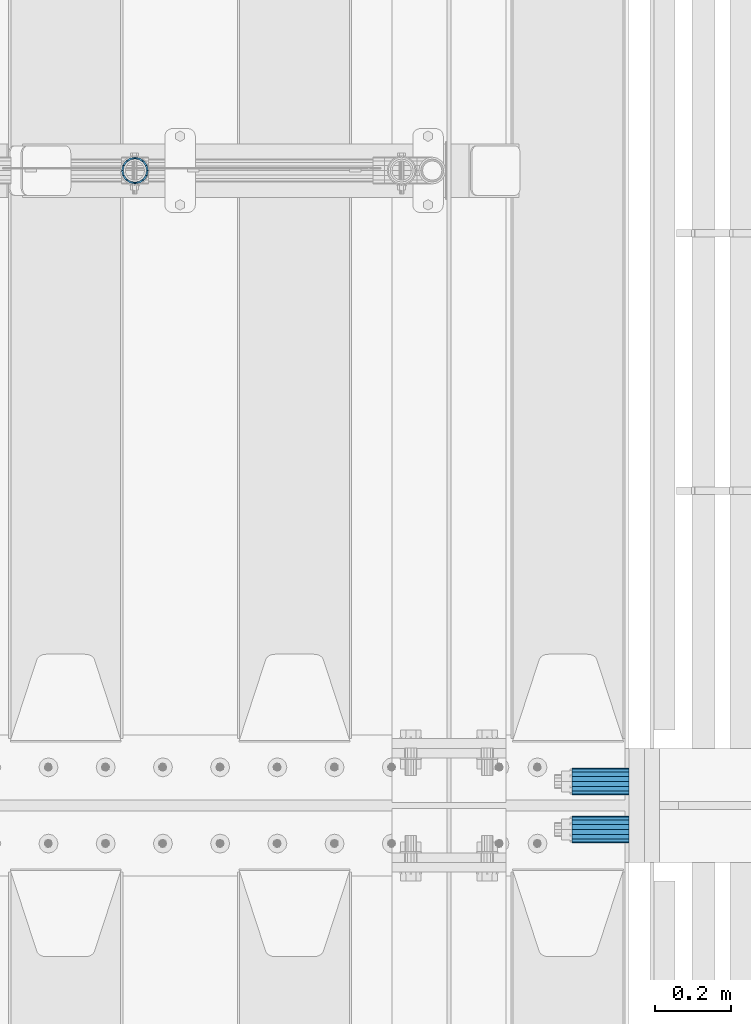
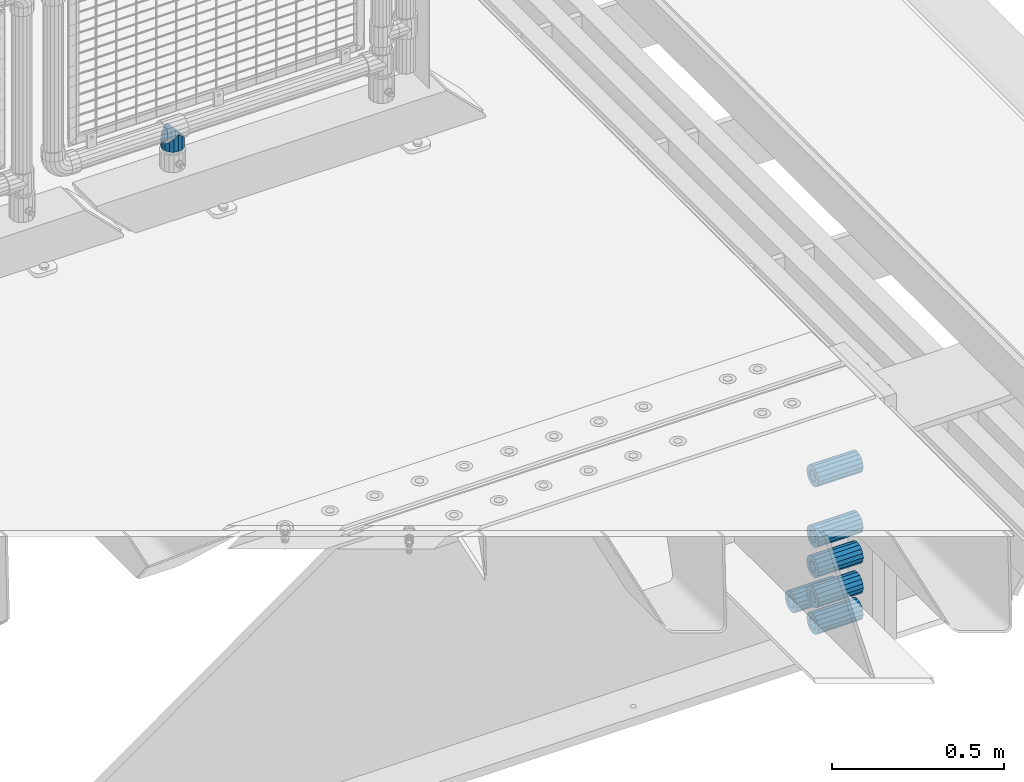
# One storey, part 156 of 240: 7 beams.
"""IFC2X3 building model written with IfcOpenShell, lengths in millimetres."""

from ifc_helpers import new_model, si_unit, frame, origin_with_axes, place, context, subcontext, project, spatial, faceted_brep, material, type_object, element, save


model = new_model("IFC2X3")

# Units and contexts
model_context = context("Model", 3, precision=1e-05, world=origin_with_axes())
body_context = subcontext(model_context, "Body", "Model", "MODEL_VIEW")
ifc_project = project(units=[si_unit("LENGTHUNIT", "METRE", prefix="MILLI"), si_unit("AREAUNIT", "SQUARE_METRE"), si_unit("VOLUMEUNIT", "CUBIC_METRE"), si_unit("MASSUNIT", "GRAM", prefix="KILO"), si_unit("TIMEUNIT", "SECOND"), si_unit("PLANEANGLEUNIT", "RADIAN"), si_unit("SOLIDANGLEUNIT", "STERADIAN"), si_unit("THERMODYNAMICTEMPERATUREUNIT", "DEGREE_CELSIUS"), si_unit("LUMINOUSINTENSITYUNIT", "LUMEN")], contexts=[model_context])

# Site, building, storey
site_placement = place(None, origin_with_axes())
site = spatial("IfcSite", under=ifc_project, at=site_placement, CompositionType="ELEMENT")
building_placement = place(site_placement, origin_with_axes())
building = spatial("IfcBuilding", under=site, at=building_placement, Name="Standard", CompositionType="ELEMENT")
storey_placement = place(building_placement, origin_with_axes())
storey = spatial("IfcBuildingStorey", under=building, at=storey_placement, Name="Undefined", CompositionType="ELEMENT", Elevation=0.0)

# Beams
ifc_material_1 = material()
beam_type_1 = type_object("IfcBeamType", PredefinedType="NOTDEFINED")
beam_1_placement = place(storey_placement, frame((56327.0, 32937.0, -285.0), z_axis=(0.0, 0.0, 1.0), x_axis=(1.0, 0.0, 0.0)))
element("IfcBeam", 1, at=beam_1_placement, inside=storey, type_object=beam_type_1, material=ifc_material_1, context=body_context, shape_type="Brep", body=[
    faceted_brep([(-1.31236447487026e-07, -18.9999999995492, -6.26459950581193e-09), (0.0, -17.5537111177146, 7.27098521493673), (150.0, -17.5537111177146, 7.27098521493673), (150.0, -19.0, 0.0), (0.0, -13.4350288425449, 13.4350288425444), (150.0, -13.4350288425449, 13.4350288425444), (0.0, -7.27098521493826, 17.5537111177144), (150.0, -7.27098521493826, 17.5537111177144), (-6.35918695479631e-09, 4.50199877377599e-10, 18.9999999937281), (150.0, 0.0, 19.0), (0.0, 7.27098521493826, 17.5537111177144), (150.0, 7.27098521493826, 17.5537111177144), (0.0, 13.4350288425449, 13.4350288425444), (150.0, 13.4350288425449, 13.4350288425444), (0.0, 17.5537111177146, 7.27098521493673), (150.0, 17.5537111177146, 7.27098521493673), (1.33248249767348e-07, 19.0000000004507, -6.26459950581193e-09), (150.0, 19.0, 0.0), (0.0, 17.5537111177146, -7.27098521493673), (150.0, 17.5537111177146, -7.27098521493673), (0.0, 13.4350288425449, -13.4350288425444), (150.0, 13.4350288425449, -13.4350288425444), (0.0, 7.27098521493826, -17.5537111177144), (150.0, 7.27098521493826, -17.5537111177144), (8.37098923511803e-09, 4.50313564215321e-10, -19.0000000062646), (150.0, 0.0, -19.0), (0.0, -7.27098521493826, -17.5537111177144), (150.0, -7.27098521493826, -17.5537111177144), (0.0, -13.4350288425449, -13.4350288425444), (150.0, -13.4350288425449, -13.4350288425444), (0.0, -17.5537111177146, -7.27098521493673), (150.0, -17.5537111177146, -7.27098521493673), (0.0, -35.0, 0.0), (7.27595761418343e-12, -32.335783637895, -13.3939201327739), (150.0, -32.3357836378964, -13.3939201327782), (150.0, -35.0, 0.0), (0.0, -24.7487373415292, -24.7487373415279), (150.0, -24.7487373415279, -24.7487373415292), (7.27595761418343e-12, -13.3939201327781, -32.3357836378891), (150.0, -13.3939201327776, -32.335783637895), (7.27595761418343e-12, 0.0, -35.0), (150.0, 0.0, -35.0), (7.27595761418343e-12, 13.3939201327782, -32.3357836378891), (150.0, 13.3939201327776, -32.335783637895), (0.0, 24.7487373415292, -24.7487373415279), (150.0, 24.7487373415279, -24.7487373415291), (7.27595761418343e-12, 32.335783637895, -13.3939201327739), (150.0, 32.3357836378964, -13.3939201327781), (0.0, 35.0, 0.0), (150.0, 35.0, 0.0), (0.0, 32.335783637895, 13.3939201327812), (150.0, 32.3357836378964, 13.3939201327781), (0.0, 24.7487373415292, 24.7487373415279), (150.0, 24.7487373415279, 24.7487373415292), (0.0, 13.3939201327781, 32.3357836378964), (150.0, 13.3939201327776, 32.335783637895), (0.0, 0.0, 35.0), (150.0, 0.0, 35.0), (0.0, -13.3939201327781, 32.3357836378964), (150.0, -13.3939201327776, 32.335783637895), (0.0, -24.7487373415292, 24.7487373415279), (150.0, -24.7487373415279, 24.7487373415292), (0.0, -32.335783637895, 13.3939201327812), (150.0, -32.3357836378964, 13.3939201327781)], [[[0, 1, 2, 3]], [[1, 4, 5, 2]], [[4, 6, 7, 5]], [[6, 8, 9, 7]], [[8, 10, 11, 9]], [[10, 12, 13, 11]], [[12, 14, 15, 13]], [[14, 16, 17, 15]], [[16, 18, 19, 17]], [[18, 20, 21, 19]], [[20, 22, 23, 21]], [[22, 24, 25, 23]], [[24, 26, 27, 25]], [[26, 28, 29, 27]], [[28, 30, 31, 29]], [[30, 0, 3, 31]], [[32, 33, 34, 35]], [[33, 36, 37, 34]], [[36, 38, 39, 37]], [[38, 40, 41, 39]], [[40, 42, 43, 41]], [[42, 44, 45, 43]], [[44, 46, 47, 45]], [[46, 48, 49, 47]], [[48, 50, 51, 49]], [[50, 52, 53, 51]], [[52, 54, 55, 53]], [[54, 56, 57, 55]], [[56, 58, 59, 57]], [[58, 60, 61, 59]], [[60, 62, 63, 61]], [[62, 32, 35, 63]], [[37, 39, 41, 43, 45, 47, 49, 51, 53, 55, 57, 59, 61, 63, 35, 34], [5, 7, 9, 11, 13, 15, 17, 19, 21, 23, 25, 27, 29, 31, 3, 2]], [[62, 60, 58, 56, 54, 52, 50, 48, 46, 44, 42, 40, 38, 36, 33, 32], [30, 28, 26, 24, 22, 20, 18, 16, 14, 12, 10, 8, 6, 4, 1, 0]]]),
])
beam_2_placement = place(storey_placement, frame((56327.0, 32937.0, -499.0), z_axis=(0.0, 0.0, 1.0), x_axis=(1.0, 0.0, 0.0)))
element("IfcBeam", 2, at=beam_2_placement, inside=storey, type_object=beam_type_1, material=ifc_material_1, context=body_context, shape_type="Brep", body=[
    faceted_brep([(-1.31236447487026e-07, -18.9999999995492, -6.26459950581193e-09), (0.0, -17.5537111177146, 7.27098521493673), (150.0, -17.5537111177146, 7.27098521493673), (150.0, -19.0, 0.0), (0.0, -13.4350288425449, 13.4350288425444), (150.0, -13.4350288425449, 13.4350288425444), (0.0, -7.27098521493826, 17.5537111177144), (150.0, -7.27098521493826, 17.5537111177144), (-6.35918695479631e-09, 4.50199877377599e-10, 18.9999999937281), (150.0, 0.0, 19.0), (0.0, 7.27098521493826, 17.5537111177144), (150.0, 7.27098521493826, 17.5537111177144), (0.0, 13.4350288425449, 13.4350288425444), (150.0, 13.4350288425449, 13.4350288425444), (0.0, 17.5537111177146, 7.27098521493673), (150.0, 17.5537111177146, 7.27098521493673), (1.33248249767348e-07, 19.0000000004507, -6.26459950581193e-09), (150.0, 19.0, 0.0), (0.0, 17.5537111177146, -7.27098521493673), (150.0, 17.5537111177146, -7.27098521493673), (0.0, 13.4350288425449, -13.4350288425444), (150.0, 13.4350288425449, -13.4350288425444), (0.0, 7.27098521493826, -17.5537111177144), (150.0, 7.27098521493826, -17.5537111177144), (8.37098923511803e-09, 4.50313564215321e-10, -19.0000000062646), (150.0, 0.0, -19.0), (0.0, -7.27098521493826, -17.5537111177144), (150.0, -7.27098521493826, -17.5537111177144), (0.0, -13.4350288425449, -13.4350288425444), (150.0, -13.4350288425449, -13.4350288425444), (0.0, -17.5537111177146, -7.27098521493673), (150.0, -17.5537111177146, -7.27098521493673), (0.0, -35.0, 0.0), (7.27595761418343e-12, -32.335783637895, -13.3939201327739), (150.0, -32.3357836378964, -13.3939201327782), (150.0, -35.0, 0.0), (0.0, -24.7487373415292, -24.7487373415279), (150.0, -24.7487373415279, -24.7487373415292), (7.27595761418343e-12, -13.3939201327781, -32.3357836378891), (150.0, -13.3939201327776, -32.335783637895), (7.27595761418343e-12, 0.0, -35.0), (150.0, 0.0, -35.0), (7.27595761418343e-12, 13.3939201327782, -32.3357836378891), (150.0, 13.3939201327776, -32.335783637895), (0.0, 24.7487373415292, -24.7487373415279), (150.0, 24.7487373415279, -24.7487373415291), (7.27595761418343e-12, 32.335783637895, -13.3939201327739), (150.0, 32.3357836378964, -13.3939201327781), (0.0, 35.0, 0.0), (150.0, 35.0, 0.0), (0.0, 32.335783637895, 13.3939201327812), (150.0, 32.3357836378964, 13.3939201327781), (0.0, 24.7487373415292, 24.7487373415279), (150.0, 24.7487373415279, 24.7487373415292), (0.0, 13.3939201327781, 32.3357836378964), (150.0, 13.3939201327776, 32.335783637895), (0.0, 0.0, 35.0), (150.0, 0.0, 35.0), (0.0, -13.3939201327781, 32.3357836378964), (150.0, -13.3939201327776, 32.335783637895), (0.0, -24.7487373415292, 24.7487373415279), (150.0, -24.7487373415279, 24.7487373415292), (0.0, -32.335783637895, 13.3939201327812), (150.0, -32.3357836378964, 13.3939201327781)], [[[0, 1, 2, 3]], [[1, 4, 5, 2]], [[4, 6, 7, 5]], [[6, 8, 9, 7]], [[8, 10, 11, 9]], [[10, 12, 13, 11]], [[12, 14, 15, 13]], [[14, 16, 17, 15]], [[16, 18, 19, 17]], [[18, 20, 21, 19]], [[20, 22, 23, 21]], [[22, 24, 25, 23]], [[24, 26, 27, 25]], [[26, 28, 29, 27]], [[28, 30, 31, 29]], [[30, 0, 3, 31]], [[32, 33, 34, 35]], [[33, 36, 37, 34]], [[36, 38, 39, 37]], [[38, 40, 41, 39]], [[40, 42, 43, 41]], [[42, 44, 45, 43]], [[44, 46, 47, 45]], [[46, 48, 49, 47]], [[48, 50, 51, 49]], [[50, 52, 53, 51]], [[52, 54, 55, 53]], [[54, 56, 57, 55]], [[56, 58, 59, 57]], [[58, 60, 61, 59]], [[60, 62, 63, 61]], [[62, 32, 35, 63]], [[37, 39, 41, 43, 45, 47, 49, 51, 53, 55, 57, 59, 61, 63, 35, 34], [5, 7, 9, 11, 13, 15, 17, 19, 21, 23, 25, 27, 29, 31, 3, 2]], [[62, 60, 58, 56, 54, 52, 50, 48, 46, 44, 42, 40, 38, 36, 33, 32], [30, 28, 26, 24, 22, 20, 18, 16, 14, 12, 10, 8, 6, 4, 1, 0]]]),
])
beam_3_placement = place(storey_placement, frame((56327.0, 32937.0, -606.0), z_axis=(0.0, 0.0, 1.0), x_axis=(1.0, 0.0, 0.0)))
element("IfcBeam", 3, at=beam_3_placement, inside=storey, type_object=beam_type_1, material=ifc_material_1, context=body_context, shape_type="Brep", body=[
    faceted_brep([(-1.31236447487026e-07, -18.9999999995492, -6.26459950581193e-09), (0.0, -17.5537111177146, 7.27098521493673), (150.0, -17.5537111177146, 7.27098521493673), (150.0, -19.0, 0.0), (0.0, -13.4350288425449, 13.4350288425444), (150.0, -13.4350288425449, 13.4350288425444), (0.0, -7.27098521493826, 17.5537111177144), (150.0, -7.27098521493826, 17.5537111177144), (-6.35918695479631e-09, 4.50199877377599e-10, 18.9999999937281), (150.0, 0.0, 19.0), (0.0, 7.27098521493826, 17.5537111177144), (150.0, 7.27098521493826, 17.5537111177144), (0.0, 13.4350288425449, 13.4350288425444), (150.0, 13.4350288425449, 13.4350288425444), (0.0, 17.5537111177146, 7.27098521493673), (150.0, 17.5537111177146, 7.27098521493673), (1.33248249767348e-07, 19.0000000004507, -6.26459950581193e-09), (150.0, 19.0, 0.0), (0.0, 17.5537111177146, -7.27098521493673), (150.0, 17.5537111177146, -7.27098521493673), (0.0, 13.4350288425449, -13.4350288425444), (150.0, 13.4350288425449, -13.4350288425444), (0.0, 7.27098521493826, -17.5537111177144), (150.0, 7.27098521493826, -17.5537111177144), (8.37098923511803e-09, 4.50313564215321e-10, -19.0000000062646), (150.0, 0.0, -19.0), (0.0, -7.27098521493826, -17.5537111177144), (150.0, -7.27098521493826, -17.5537111177144), (0.0, -13.4350288425449, -13.4350288425444), (150.0, -13.4350288425449, -13.4350288425444), (0.0, -17.5537111177146, -7.27098521493673), (150.0, -17.5537111177146, -7.27098521493673), (0.0, -35.0, 0.0), (7.27595761418343e-12, -32.335783637895, -13.3939201327739), (150.0, -32.3357836378964, -13.3939201327782), (150.0, -35.0, 0.0), (0.0, -24.7487373415292, -24.7487373415279), (150.0, -24.7487373415279, -24.7487373415292), (7.27595761418343e-12, -13.3939201327781, -32.3357836378891), (150.0, -13.3939201327776, -32.335783637895), (7.27595761418343e-12, 0.0, -35.0), (150.0, 0.0, -35.0), (7.27595761418343e-12, 13.3939201327782, -32.3357836378891), (150.0, 13.3939201327776, -32.335783637895), (0.0, 24.7487373415292, -24.7487373415279), (150.0, 24.7487373415279, -24.7487373415291), (7.27595761418343e-12, 32.335783637895, -13.3939201327739), (150.0, 32.3357836378964, -13.3939201327781), (0.0, 35.0, 0.0), (150.0, 35.0, 0.0), (0.0, 32.335783637895, 13.3939201327812), (150.0, 32.3357836378964, 13.3939201327781), (0.0, 24.7487373415292, 24.7487373415279), (150.0, 24.7487373415279, 24.7487373415292), (0.0, 13.3939201327781, 32.3357836378964), (150.0, 13.3939201327776, 32.335783637895), (0.0, 0.0, 35.0), (150.0, 0.0, 35.0), (0.0, -13.3939201327781, 32.3357836378964), (150.0, -13.3939201327776, 32.335783637895), (0.0, -24.7487373415292, 24.7487373415279), (150.0, -24.7487373415279, 24.7487373415292), (0.0, -32.335783637895, 13.3939201327812), (150.0, -32.3357836378964, 13.3939201327781)], [[[0, 1, 2, 3]], [[1, 4, 5, 2]], [[4, 6, 7, 5]], [[6, 8, 9, 7]], [[8, 10, 11, 9]], [[10, 12, 13, 11]], [[12, 14, 15, 13]], [[14, 16, 17, 15]], [[16, 18, 19, 17]], [[18, 20, 21, 19]], [[20, 22, 23, 21]], [[22, 24, 25, 23]], [[24, 26, 27, 25]], [[26, 28, 29, 27]], [[28, 30, 31, 29]], [[30, 0, 3, 31]], [[32, 33, 34, 35]], [[33, 36, 37, 34]], [[36, 38, 39, 37]], [[38, 40, 41, 39]], [[40, 42, 43, 41]], [[42, 44, 45, 43]], [[44, 46, 47, 45]], [[46, 48, 49, 47]], [[48, 50, 51, 49]], [[50, 52, 53, 51]], [[52, 54, 55, 53]], [[54, 56, 57, 55]], [[56, 58, 59, 57]], [[58, 60, 61, 59]], [[60, 62, 63, 61]], [[62, 32, 35, 63]], [[37, 39, 41, 43, 45, 47, 49, 51, 53, 55, 57, 59, 61, 63, 35, 34], [5, 7, 9, 11, 13, 15, 17, 19, 21, 23, 25, 27, 29, 31, 3, 2]], [[62, 60, 58, 56, 54, 52, 50, 48, 46, 44, 42, 40, 38, 36, 33, 32], [30, 28, 26, 24, 22, 20, 18, 16, 14, 12, 10, 8, 6, 4, 1, 0]]]),
])
beam_4_placement = place(storey_placement, frame((56327.0, 32937.0, -713.0), z_axis=(0.0, 0.0, 1.0), x_axis=(1.0, 0.0, 0.0)))
element("IfcBeam", 4, at=beam_4_placement, inside=storey, type_object=beam_type_1, material=ifc_material_1, context=body_context, shape_type="Brep", body=[
    faceted_brep([(-1.31236447487026e-07, -18.9999999995492, -6.26459950581193e-09), (0.0, -17.5537111177146, 7.27098521493673), (150.0, -17.5537111177146, 7.27098521493673), (150.0, -19.0, 0.0), (0.0, -13.4350288425449, 13.4350288425444), (150.0, -13.4350288425449, 13.4350288425444), (0.0, -7.27098521493826, 17.5537111177144), (150.0, -7.27098521493826, 17.5537111177144), (-6.35918695479631e-09, 4.50199877377599e-10, 18.9999999937281), (150.0, 0.0, 19.0), (0.0, 7.27098521493826, 17.5537111177144), (150.0, 7.27098521493826, 17.5537111177144), (0.0, 13.4350288425449, 13.4350288425444), (150.0, 13.4350288425449, 13.4350288425444), (0.0, 17.5537111177146, 7.27098521493673), (150.0, 17.5537111177146, 7.27098521493673), (1.33248249767348e-07, 19.0000000004507, -6.26459950581193e-09), (150.0, 19.0, 0.0), (0.0, 17.5537111177146, -7.27098521493673), (150.0, 17.5537111177146, -7.27098521493673), (0.0, 13.4350288425449, -13.4350288425444), (150.0, 13.4350288425449, -13.4350288425444), (0.0, 7.27098521493826, -17.5537111177144), (150.0, 7.27098521493826, -17.5537111177144), (8.37098923511803e-09, 4.50313564215321e-10, -19.0000000062646), (150.0, 0.0, -19.0), (0.0, -7.27098521493826, -17.5537111177144), (150.0, -7.27098521493826, -17.5537111177144), (0.0, -13.4350288425449, -13.4350288425444), (150.0, -13.4350288425449, -13.4350288425444), (0.0, -17.5537111177146, -7.27098521493673), (150.0, -17.5537111177146, -7.27098521493673), (0.0, -35.0, 0.0), (7.27595761418343e-12, -32.335783637895, -13.3939201327739), (150.0, -32.3357836378964, -13.3939201327782), (150.0, -35.0, 0.0), (0.0, -24.7487373415292, -24.7487373415279), (150.0, -24.7487373415279, -24.7487373415292), (7.27595761418343e-12, -13.3939201327781, -32.3357836378891), (150.0, -13.3939201327776, -32.335783637895), (7.27595761418343e-12, 0.0, -35.0), (150.0, 0.0, -35.0), (7.27595761418343e-12, 13.3939201327782, -32.3357836378891), (150.0, 13.3939201327776, -32.335783637895), (0.0, 24.7487373415292, -24.7487373415279), (150.0, 24.7487373415279, -24.7487373415291), (7.27595761418343e-12, 32.335783637895, -13.3939201327739), (150.0, 32.3357836378964, -13.3939201327781), (0.0, 35.0, 0.0), (150.0, 35.0, 0.0), (0.0, 32.335783637895, 13.3939201327812), (150.0, 32.3357836378964, 13.3939201327781), (0.0, 24.7487373415292, 24.7487373415279), (150.0, 24.7487373415279, 24.7487373415292), (0.0, 13.3939201327781, 32.3357836378964), (150.0, 13.3939201327776, 32.335783637895), (0.0, 0.0, 35.0), (150.0, 0.0, 35.0), (0.0, -13.3939201327781, 32.3357836378964), (150.0, -13.3939201327776, 32.335783637895), (0.0, -24.7487373415292, 24.7487373415279), (150.0, -24.7487373415279, 24.7487373415292), (0.0, -32.335783637895, 13.3939201327812), (150.0, -32.3357836378964, 13.3939201327781)], [[[0, 1, 2, 3]], [[1, 4, 5, 2]], [[4, 6, 7, 5]], [[6, 8, 9, 7]], [[8, 10, 11, 9]], [[10, 12, 13, 11]], [[12, 14, 15, 13]], [[14, 16, 17, 15]], [[16, 18, 19, 17]], [[18, 20, 21, 19]], [[20, 22, 23, 21]], [[22, 24, 25, 23]], [[24, 26, 27, 25]], [[26, 28, 29, 27]], [[28, 30, 31, 29]], [[30, 0, 3, 31]], [[32, 33, 34, 35]], [[33, 36, 37, 34]], [[36, 38, 39, 37]], [[38, 40, 41, 39]], [[40, 42, 43, 41]], [[42, 44, 45, 43]], [[44, 46, 47, 45]], [[46, 48, 49, 47]], [[48, 50, 51, 49]], [[50, 52, 53, 51]], [[52, 54, 55, 53]], [[54, 56, 57, 55]], [[56, 58, 59, 57]], [[58, 60, 61, 59]], [[60, 62, 63, 61]], [[62, 32, 35, 63]], [[37, 39, 41, 43, 45, 47, 49, 51, 53, 55, 57, 59, 61, 63, 35, 34], [5, 7, 9, 11, 13, 15, 17, 19, 21, 23, 25, 27, 29, 31, 3, 2]], [[62, 60, 58, 56, 54, 52, 50, 48, 46, 44, 42, 40, 38, 36, 33, 32], [30, 28, 26, 24, 22, 20, 18, 16, 14, 12, 10, 8, 6, 4, 1, 0]]]),
])
beam_5_placement = place(storey_placement, frame((56327.0, 33063.0, -807.0), z_axis=(0.0, 0.0, 1.0), x_axis=(1.0, 0.0, 0.0)))
element("IfcBeam", 5, at=beam_5_placement, inside=storey, type_object=beam_type_1, material=ifc_material_1, context=body_context, shape_type="Brep", body=[
    faceted_brep([(-1.31236447487026e-07, -18.9999999995492, -6.26459950581193e-09), (0.0, -17.5537111177146, 7.27098521493673), (150.0, -17.5537111177146, 7.27098521493673), (150.0, -19.0, 0.0), (0.0, -13.4350288425449, 13.4350288425444), (150.0, -13.4350288425449, 13.4350288425444), (0.0, -7.27098521493826, 17.5537111177144), (150.0, -7.27098521493826, 17.5537111177144), (-6.35918695479631e-09, 4.50199877377599e-10, 18.9999999937281), (150.0, 0.0, 19.0), (0.0, 7.27098521493826, 17.5537111177144), (150.0, 7.27098521493826, 17.5537111177144), (0.0, 13.4350288425449, 13.4350288425444), (150.0, 13.4350288425449, 13.4350288425444), (0.0, 17.5537111177146, 7.27098521493673), (150.0, 17.5537111177146, 7.27098521493673), (1.33248249767348e-07, 19.0000000004507, -6.26459950581193e-09), (150.0, 19.0, 0.0), (0.0, 17.5537111177146, -7.27098521493673), (150.0, 17.5537111177146, -7.27098521493673), (0.0, 13.4350288425449, -13.4350288425444), (150.0, 13.4350288425449, -13.4350288425444), (0.0, 7.27098521493826, -17.5537111177144), (150.0, 7.27098521493826, -17.5537111177144), (8.37098923511803e-09, 4.50313564215321e-10, -19.0000000062646), (150.0, 0.0, -19.0), (0.0, -7.27098521493826, -17.5537111177144), (150.0, -7.27098521493826, -17.5537111177144), (0.0, -13.4350288425449, -13.4350288425444), (150.0, -13.4350288425449, -13.4350288425444), (0.0, -17.5537111177146, -7.27098521493673), (150.0, -17.5537111177146, -7.27098521493673), (0.0, -35.0, 0.0), (7.27595761418343e-12, -32.335783637895, -13.3939201327739), (150.0, -32.3357836378964, -13.3939201327782), (150.0, -35.0, 0.0), (0.0, -24.7487373415292, -24.7487373415279), (150.0, -24.7487373415279, -24.7487373415292), (7.27595761418343e-12, -13.3939201327781, -32.3357836378891), (150.0, -13.3939201327776, -32.335783637895), (7.27595761418343e-12, 0.0, -35.0), (150.0, 0.0, -35.0), (7.27595761418343e-12, 13.3939201327782, -32.3357836378891), (150.0, 13.3939201327776, -32.335783637895), (0.0, 24.7487373415292, -24.7487373415279), (150.0, 24.7487373415279, -24.7487373415291), (7.27595761418343e-12, 32.335783637895, -13.3939201327739), (150.0, 32.3357836378964, -13.3939201327781), (0.0, 35.0, 0.0), (150.0, 35.0, 0.0), (0.0, 32.335783637895, 13.3939201327812), (150.0, 32.3357836378964, 13.3939201327781), (0.0, 24.7487373415292, 24.7487373415279), (150.0, 24.7487373415279, 24.7487373415292), (0.0, 13.3939201327781, 32.3357836378964), (150.0, 13.3939201327776, 32.335783637895), (0.0, 0.0, 35.0), (150.0, 0.0, 35.0), (0.0, -13.3939201327781, 32.3357836378964), (150.0, -13.3939201327776, 32.335783637895), (0.0, -24.7487373415292, 24.7487373415279), (150.0, -24.7487373415279, 24.7487373415292), (0.0, -32.335783637895, 13.3939201327812), (150.0, -32.3357836378964, 13.3939201327781)], [[[0, 1, 2, 3]], [[1, 4, 5, 2]], [[4, 6, 7, 5]], [[6, 8, 9, 7]], [[8, 10, 11, 9]], [[10, 12, 13, 11]], [[12, 14, 15, 13]], [[14, 16, 17, 15]], [[16, 18, 19, 17]], [[18, 20, 21, 19]], [[20, 22, 23, 21]], [[22, 24, 25, 23]], [[24, 26, 27, 25]], [[26, 28, 29, 27]], [[28, 30, 31, 29]], [[30, 0, 3, 31]], [[32, 33, 34, 35]], [[33, 36, 37, 34]], [[36, 38, 39, 37]], [[38, 40, 41, 39]], [[40, 42, 43, 41]], [[42, 44, 45, 43]], [[44, 46, 47, 45]], [[46, 48, 49, 47]], [[48, 50, 51, 49]], [[50, 52, 53, 51]], [[52, 54, 55, 53]], [[54, 56, 57, 55]], [[56, 58, 59, 57]], [[58, 60, 61, 59]], [[60, 62, 63, 61]], [[62, 32, 35, 63]], [[37, 39, 41, 43, 45, 47, 49, 51, 53, 55, 57, 59, 61, 63, 35, 34], [5, 7, 9, 11, 13, 15, 17, 19, 21, 23, 25, 27, 29, 31, 3, 2]], [[62, 60, 58, 56, 54, 52, 50, 48, 46, 44, 42, 40, 38, 36, 33, 32], [30, 28, 26, 24, 22, 20, 18, 16, 14, 12, 10, 8, 6, 4, 1, 0]]]),
])
beam_6_placement = place(storey_placement, frame((56327.0, 32937.0, -807.0), z_axis=(0.0, 0.0, 1.0), x_axis=(1.0, 0.0, 0.0)))
element("IfcBeam", 6, at=beam_6_placement, inside=storey, type_object=beam_type_1, material=ifc_material_1, context=body_context, shape_type="Brep", body=[
    faceted_brep([(-1.31236447487026e-07, -18.9999999995492, -6.26459950581193e-09), (0.0, -17.5537111177146, 7.27098521493673), (150.0, -17.5537111177146, 7.27098521493673), (150.0, -19.0, 0.0), (0.0, -13.4350288425449, 13.4350288425444), (150.0, -13.4350288425449, 13.4350288425444), (0.0, -7.27098521493826, 17.5537111177144), (150.0, -7.27098521493826, 17.5537111177144), (-6.35918695479631e-09, 4.50199877377599e-10, 18.9999999937281), (150.0, 0.0, 19.0), (0.0, 7.27098521493826, 17.5537111177144), (150.0, 7.27098521493826, 17.5537111177144), (0.0, 13.4350288425449, 13.4350288425444), (150.0, 13.4350288425449, 13.4350288425444), (0.0, 17.5537111177146, 7.27098521493673), (150.0, 17.5537111177146, 7.27098521493673), (1.33248249767348e-07, 19.0000000004507, -6.26459950581193e-09), (150.0, 19.0, 0.0), (0.0, 17.5537111177146, -7.27098521493673), (150.0, 17.5537111177146, -7.27098521493673), (0.0, 13.4350288425449, -13.4350288425444), (150.0, 13.4350288425449, -13.4350288425444), (0.0, 7.27098521493826, -17.5537111177144), (150.0, 7.27098521493826, -17.5537111177144), (8.37098923511803e-09, 4.50313564215321e-10, -19.0000000062646), (150.0, 0.0, -19.0), (0.0, -7.27098521493826, -17.5537111177144), (150.0, -7.27098521493826, -17.5537111177144), (0.0, -13.4350288425449, -13.4350288425444), (150.0, -13.4350288425449, -13.4350288425444), (0.0, -17.5537111177146, -7.27098521493673), (150.0, -17.5537111177146, -7.27098521493673), (0.0, -35.0, 0.0), (7.27595761418343e-12, -32.335783637895, -13.3939201327739), (150.0, -32.3357836378964, -13.3939201327782), (150.0, -35.0, 0.0), (0.0, -24.7487373415292, -24.7487373415279), (150.0, -24.7487373415279, -24.7487373415292), (7.27595761418343e-12, -13.3939201327781, -32.3357836378891), (150.0, -13.3939201327776, -32.335783637895), (7.27595761418343e-12, 0.0, -35.0), (150.0, 0.0, -35.0), (7.27595761418343e-12, 13.3939201327782, -32.3357836378891), (150.0, 13.3939201327776, -32.335783637895), (0.0, 24.7487373415292, -24.7487373415279), (150.0, 24.7487373415279, -24.7487373415291), (7.27595761418343e-12, 32.335783637895, -13.3939201327739), (150.0, 32.3357836378964, -13.3939201327781), (0.0, 35.0, 0.0), (150.0, 35.0, 0.0), (0.0, 32.335783637895, 13.3939201327812), (150.0, 32.3357836378964, 13.3939201327781), (0.0, 24.7487373415292, 24.7487373415279), (150.0, 24.7487373415279, 24.7487373415292), (0.0, 13.3939201327781, 32.3357836378964), (150.0, 13.3939201327776, 32.335783637895), (0.0, 0.0, 35.0), (150.0, 0.0, 35.0), (0.0, -13.3939201327781, 32.3357836378964), (150.0, -13.3939201327776, 32.335783637895), (0.0, -24.7487373415292, 24.7487373415279), (150.0, -24.7487373415279, 24.7487373415292), (0.0, -32.335783637895, 13.3939201327812), (150.0, -32.3357836378964, 13.3939201327781)], [[[0, 1, 2, 3]], [[1, 4, 5, 2]], [[4, 6, 7, 5]], [[6, 8, 9, 7]], [[8, 10, 11, 9]], [[10, 12, 13, 11]], [[12, 14, 15, 13]], [[14, 16, 17, 15]], [[16, 18, 19, 17]], [[18, 20, 21, 19]], [[20, 22, 23, 21]], [[22, 24, 25, 23]], [[24, 26, 27, 25]], [[26, 28, 29, 27]], [[28, 30, 31, 29]], [[30, 0, 3, 31]], [[32, 33, 34, 35]], [[33, 36, 37, 34]], [[36, 38, 39, 37]], [[38, 40, 41, 39]], [[40, 42, 43, 41]], [[42, 44, 45, 43]], [[44, 46, 47, 45]], [[46, 48, 49, 47]], [[48, 50, 51, 49]], [[50, 52, 53, 51]], [[52, 54, 55, 53]], [[54, 56, 57, 55]], [[56, 58, 59, 57]], [[58, 60, 61, 59]], [[60, 62, 63, 61]], [[62, 32, 35, 63]], [[37, 39, 41, 43, 45, 47, 49, 51, 53, 55, 57, 59, 61, 63, 35, 34], [5, 7, 9, 11, 13, 15, 17, 19, 21, 23, 25, 27, 29, 31, 3, 2]], [[62, 60, 58, 56, 54, 52, 50, 48, 46, 44, 42, 40, 38, 36, 33, 32], [30, 28, 26, 24, 22, 20, 18, 16, 14, 12, 10, 8, 6, 4, 1, 0]]]),
])
ifc_material_2 = material(Name="Misc_Undefined")
beam_type_2 = type_object("IfcBeamType", PredefinedType="NOTDEFINED")
beam_7_placement = place(storey_placement, frame((55181.61, 34664.5, 298.169999999999), z_axis=(0.0, 1.0, 0.0), x_axis=(0.0, 0.0, -1.0)))
element("IfcBeam", 7, at=beam_7_placement, inside=storey, type_object=beam_type_2, material=ifc_material_2, context=body_context, shape_type="Brep", body=[
    faceted_brep([(0.0, 0.0, 35.1500000000015), (13.4513226476338, 13.4513226476329, 32.4743655677739), (13.4513226476338, -13.4513226476329, 32.4743655677739), (24.8548033587067, -16.3810424079947, -24.8548033587067), (24.8548033587067, -24.8548033587072, -24.8548033587067), (32.4743655677739, -32.4743655677717, -13.4513226476338), (32.4743655677739, -26.8123795176712, -13.4513226476338), (27.1226768591223, -21.4606908090117, -21.4606908090136), (0.0, 0.0, -35.1500000000015), (13.4513226476338, -13.4513226476329, -32.4743655677739), (13.4513226476338, 13.4513226476329, -32.4743655677739), (20.0882031229994, -11.6144421722805, -28.0397438117143), (16.6306603983758, 0.0, -30.3499999999985), (20.0882031229994, 11.6144421722805, -28.0397438117143), (24.8548033587067, 16.3810424080013, -24.8548033587067), (24.8548033587067, 24.8548033587072, -24.8548033587067), (27.1226768591223, 21.4606908090117, -21.4606908090136), (32.4743655677739, 26.8123795176712, -13.4513226476338), (32.4743655677739, 32.4743655677717, -13.4513226476338), (32.8397438117172, 28.0397438117175, -11.6144421722784), (35.1500000000015, 30.35, 0.0), (35.1500000000015, 35.15, 0.0), (32.8397438117099, 28.0397438117175, 11.6144421722784), (32.4743655677739, 26.8123795176755, 13.4513226476338), (32.4743655677739, 32.4743655677717, 13.4513226476338), (27.1226768591005, 21.4606908090117, 21.4606908090136), (24.8548033587067, 16.3810424080013, 24.8548033587067), (24.8548033587067, 24.8548033587072, 24.8548033587067), (20.0882031229849, 11.6144421722805, 28.0397438117143), (16.6306603983685, 0.0, 30.3499999999985), (20.0882031229849, -11.6144421722805, 28.0397438117143), (24.8548033587067, -16.3810424080078, 24.8548033587067), (24.8548033587067, -24.8548033587072, 24.8548033587067), (27.1226768591005, -21.4606908090117, 21.4606908090136), (32.4743655677739, -26.8123795176712, 13.4513226476338), (32.4743655677739, -32.4743655677717, 13.4513226476338), (32.8397438117099, -28.0397438117175, 11.6144421722784), (35.1500000000015, -30.35, 0.0), (35.1500000000015, -35.15, 0.0), (32.8397438117172, -28.0397438117175, -11.6144421722784), (60.1500000000015, -24.8548033587072, -24.8548033587067), (60.1500000000015, -32.4743655677717, -13.4513226476338), (60.1500000000015, -13.4513226476329, -32.4743655677739), (60.1500000000015, 0.0, -35.1500000000015), (60.1500000000015, 13.4513226476329, -32.4743655677739), (60.1500000000015, 24.8548033587072, -24.8548033587067), (60.1500000000015, 32.4743655677717, -13.4513226476338), (60.1500000000015, 35.15, 0.0), (60.1500000000015, 32.4743655677717, 13.4513226476338), (60.1500000000015, 24.8548033587072, 24.8548033587067), (60.1500000000015, 13.4513226476329, 32.4743655677739), (60.1500000000015, 0.0, 35.1500000000015), (60.1500000000015, -13.4513226476329, 32.4743655677739), (60.1500000000015, -24.8548033587072, 24.8548033587067), (60.1500000000015, -32.4743655677717, 13.4513226476338), (60.1500000000015, -35.15, 0.0), (60.1500000000015, -21.4606908090117, 21.4606908090136), (60.1500000000015, -11.6144421722805, 28.0397438117143), (60.1500000000015, 0.0, 30.3499999999985), (60.1500000000015, 11.6144421722805, 28.0397438117143), (60.1500000000015, 21.4606908090117, 21.4606908090136), (60.1500000000015, 28.0397438117175, 11.6144421722784), (60.1500000000015, 30.35, 0.0), (60.1500000000015, 28.0397438117175, -11.6144421722784), (60.1500000000015, 21.4606908090117, -21.4606908090136), (60.1500000000015, 11.6144421722805, -28.0397438117143), (60.1500000000015, 0.0, -30.3499999999985), (60.1500000000015, -11.6144421722805, -28.0397438117143), (60.1500000000015, -21.4606908090117, -21.4606908090136), (60.1500000000015, -28.0397438117175, -11.6144421722784), (60.1500000000015, -30.35, 0.0), (60.1500000000015, -28.0397438117175, 11.6144421722784)], [[[0, 1, 2]], [[3, 4, 5, 6, 7]], [[8, 9, 10]], [[10, 9, 4, 3, 11, 12, 13, 14, 15]], [[15, 14, 16, 17, 18]], [[18, 17, 19, 20, 21]], [[21, 20, 22, 23, 24]], [[24, 23, 25, 26, 27]], [[27, 26, 28, 29, 30, 31, 32, 2, 1]], [[33, 34, 35, 32, 31]], [[36, 37, 38, 35, 34]], [[6, 5, 38, 37, 39]], [[40, 41, 5, 4]], [[42, 40, 4, 9]], [[43, 42, 9, 8]], [[44, 43, 8, 10]], [[45, 44, 10, 15]], [[46, 45, 15, 18]], [[47, 46, 18, 21]], [[48, 47, 21, 24]], [[49, 48, 24, 27]], [[50, 49, 27, 1]], [[51, 50, 1, 0]], [[52, 51, 0, 2]], [[53, 52, 2, 32]], [[54, 53, 32, 35]], [[55, 54, 35, 38]], [[41, 55, 38, 5]], [[40, 42, 43, 44, 45, 46, 47, 48, 49, 50, 51, 52, 53, 54, 55, 41], [56, 57, 58, 59, 60, 61, 62, 63, 64, 65, 66, 67, 68, 69, 70, 71]], [[71, 70, 37, 36]], [[56, 71, 36, 34, 33]], [[57, 56, 33, 31, 30]], [[58, 57, 30, 29]], [[59, 58, 29, 28]], [[25, 60, 59, 28, 26]], [[22, 61, 60, 25, 23]], [[62, 61, 22, 20]], [[63, 62, 20, 19]], [[64, 63, 19, 17, 16]], [[65, 64, 16, 14, 13]], [[66, 65, 13, 12]], [[67, 66, 12, 11]], [[7, 68, 67, 11, 3]], [[39, 69, 68, 7, 6]], [[70, 69, 39, 37]]]),
])

save(model, "model.ifc")
